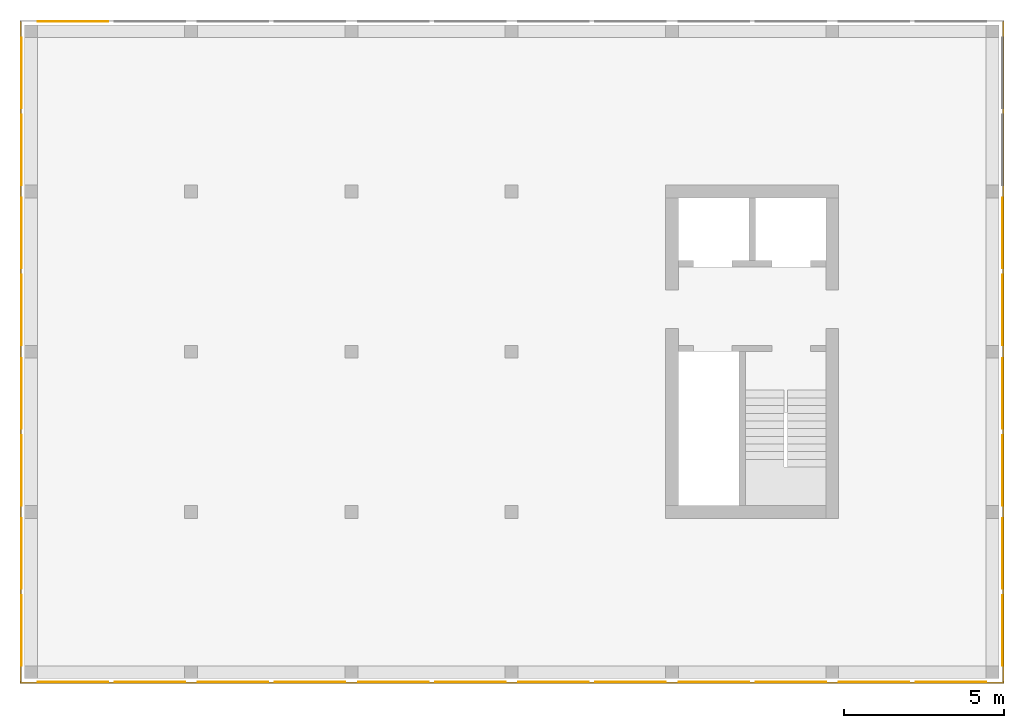
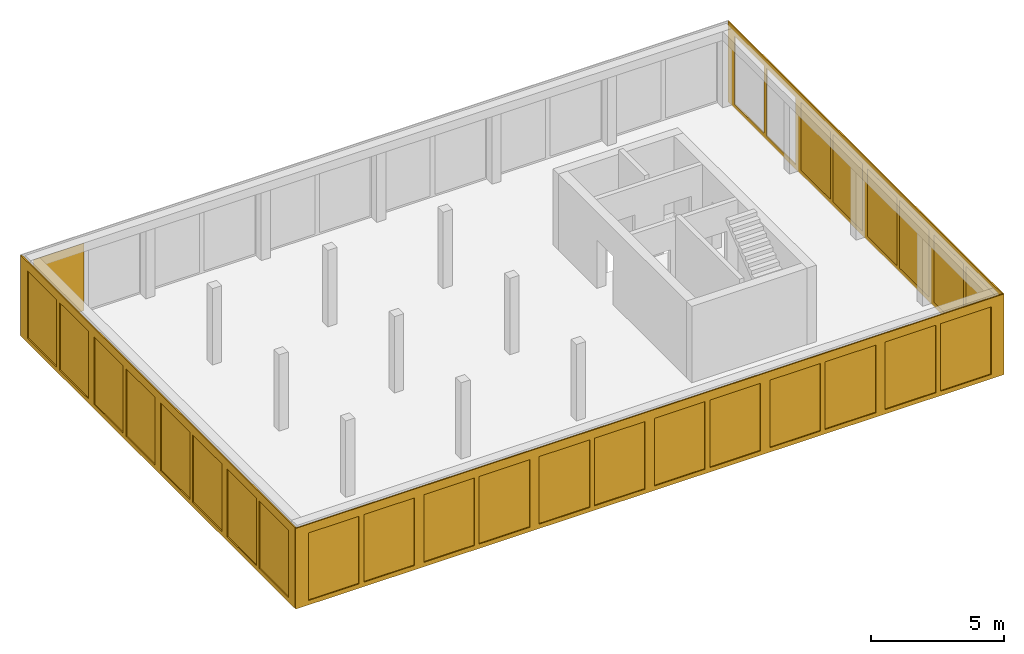
# One storey, part 3 of 4: 30 curtain walls.
"""IFC2X3 building model written with IfcOpenShell, lengths in metres."""

from ifc_helpers import new_model, entity, si_unit, converted_unit, frame, origin, place, context, subcontext, project, spatial, faceted_brep, material, element, save


model = new_model("IFC2X3")

# Units and contexts
model_context = context("Model", 3, precision=1e-05, world=origin())
body_context = subcontext(model_context, "Body", "Model", "MODEL_VIEW")
ifc_project = project(units=[si_unit("LENGTHUNIT", "METRE"), si_unit("AREAUNIT", "SQUARE_METRE"), si_unit("VOLUMEUNIT", "CUBIC_METRE"), si_unit("MASSUNIT", "GRAM", prefix="KILO"), converted_unit("PLANEANGLEUNIT", "DEGREE", entity("IfcPlaneAngleMeasure", 0.0174532925199433), si_unit("PLANEANGLEUNIT", "RADIAN"), dimensions=[0, 0, 0, 0, 0, 0, 0])], contexts=[model_context])

# Site, building, storey
site_placement = place(None, origin())
site = spatial("IfcSite", under=ifc_project, at=site_placement, CompositionType="ELEMENT")
building_placement = place(site_placement, origin())
building = spatial("IfcBuilding", under=site, at=building_placement, CompositionType="ELEMENT")
storey_placement = place(building_placement, frame((0.0, 0.0, 4.9)))
storey = spatial("IfcBuildingStorey", under=building, at=storey_placement, Name="1. Obergeschoss", CompositionType="ELEMENT", Elevation=4.9)

# Curtain walls
ifc_material_1 = material(Name="ALU")
curtain_wall_1_placement = place(storey_placement, frame((-0.139330706017223, -0.15, -0.2)))
element("IfcCurtainWall", 1, at=curtain_wall_1_placement, inside=storey, material=ifc_material_1, Name="Profil SN standard", context=body_context, shape_type="Brep", body=[
    faceted_brep([(30.7, 0.0500000000000003, 9.09494701772928e-16), (0.0, 0.0500000000000003, 9.09494701772928e-16), (0.0, 3.41060513164848e-16, 9.09494701772928e-16), (30.7, 3.41060513164848e-16, 9.09494701772928e-16), (0.0, 0.0500000000000004, 3.7), (30.7, 0.0500000000000003, 3.7), (30.7, 3.41060513164848e-16, 3.7), (0.0, 3.41060513164848e-16, 3.7), (25.15, 5.6843418860808e-17, 0.2), (25.15, 0.0500000000000001, 0.2), (25.15, 0.0500000000000001, 3.3), (25.15, 5.6843418860808e-17, 3.3), (25.55, 0.0500000000000001, 0.2), (25.55, 5.6843418860808e-17, 0.2), (25.55, 5.6843418860808e-17, 3.3), (25.55, 0.0500000000000001, 3.3), (20.15, 8.5265128291212e-17, 0.2), (20.15, 0.0500000000000001, 0.2), (20.15, 0.0500000000000001, 3.3), (20.15, 8.5265128291212e-17, 3.3), (20.55, 0.0500000000000001, 0.2), (20.55, 8.5265128291212e-17, 0.2), (20.55, 8.5265128291212e-17, 3.3), (20.55, 0.0500000000000001, 3.3), (30.15, 0.0, 0.2), (30.15, 0.05, 0.2), (30.15, 0.05, 3.3), (30.15, 0.0, 3.3), (22.75, 2.8421709430404e-16, 0.2), (22.75, 0.0500000000000003, 0.2), (22.75, 0.0500000000000003, 3.3), (22.75, 2.8421709430404e-16, 3.3), (22.95, 0.0500000000000003, 0.2), (22.95, 2.8421709430404e-16, 0.2), (22.95, 2.8421709430404e-16, 3.3), (22.95, 0.0500000000000003, 3.3), (17.75, 3.41060513164848e-16, 0.200000000000001), (17.75, 0.0500000000000003, 0.200000000000001), (17.75, 0.0500000000000003, 3.3), (17.75, 3.41060513164848e-16, 3.3), (17.95, 0.0500000000000003, 0.200000000000001), (17.95, 3.41060513164848e-16, 0.200000000000001), (17.95, 3.41060513164848e-16, 3.3), (17.95, 0.0500000000000003, 3.3), (27.75, 3.41060513164848e-16, 0.200000000000001), (27.75, 0.0500000000000003, 0.200000000000001), (27.75, 0.0500000000000003, 3.3), (27.75, 3.41060513164848e-16, 3.3), (27.95, 0.0500000000000003, 0.200000000000001), (27.95, 3.41060513164848e-16, 0.200000000000001), (27.95, 3.41060513164848e-16, 3.3), (27.95, 0.0500000000000003, 3.3), (2.75, 3.41060513164848e-16, 0.200000000000001), (2.75, 0.0500000000000003, 0.200000000000001), (2.75, 0.0500000000000003, 3.3), (2.75, 3.41060513164848e-16, 3.3), (2.95, 0.0500000000000003, 0.200000000000001), (2.95, 3.41060513164848e-16, 0.200000000000001), (2.95, 3.41060513164848e-16, 3.3), (2.95, 0.0500000000000003, 3.3), (12.75, 3.41060513164848e-16, 0.200000000000001), (12.75, 0.0500000000000003, 0.200000000000001), (12.75, 0.0500000000000003, 3.3), (12.75, 3.41060513164848e-16, 3.3), (12.95, 0.0500000000000003, 0.200000000000001), (12.95, 3.41060513164848e-16, 0.200000000000001), (12.95, 3.41060513164848e-16, 3.3), (12.95, 0.0500000000000003, 3.3), (7.75, 3.41060513164848e-16, 0.200000000000001), (7.75, 0.0500000000000003, 0.200000000000001), (7.75, 0.0500000000000003, 3.3), (7.75, 3.41060513164848e-16, 3.3), (7.95, 0.0500000000000003, 0.200000000000001), (7.95, 3.41060513164848e-16, 0.200000000000001), (7.95, 3.41060513164848e-16, 3.3), (7.95, 0.0500000000000003, 3.3), (15.55, 3.41060513164848e-16, 0.200000000000001), (15.55, 0.0500000000000003, 0.200000000000001), (15.55, 3.41060513164848e-16, 3.3), (15.55, 0.0500000000000003, 3.3), (10.55, 0.0500000000000002, 3.3), (10.55, 1.70530256582424e-16, 3.3), (15.15, 3.41060513164848e-16, 3.3), (15.15, 0.0500000000000003, 3.3), (15.15, 3.41060513164848e-16, 0.200000000000001), (15.15, 0.0500000000000003, 0.200000000000001), (10.55, 3.41060513164848e-16, 0.200000000000001), (10.55, 0.0500000000000003, 0.200000000000001), (0.550000000000004, 0.0500000000000003, 3.3), (0.550000000000004, 2.8421709430404e-16, 3.3), (5.15, 2.27373675443232e-16, 3.3), (5.15, 0.0500000000000003, 3.3), (5.15, 3.41060513164848e-16, 0.200000000000001), (5.15, 0.0500000000000003, 0.200000000000001), (0.550000000000004, 2.8421709430404e-16, 0.2), (0.550000000000004, 0.0500000000000003, 0.2), (5.55, 0.0500000000000003, 0.200000000000001), (5.55, 3.41060513164848e-16, 0.200000000000001), (5.55, 2.27373675443232e-16, 3.3), (5.55, 0.0500000000000003, 3.3), (10.15, 1.70530256582424e-16, 3.3), (10.15, 0.0500000000000002, 3.3), (10.15, 3.41060513164848e-16, 0.200000000000001), (10.15, 0.0500000000000003, 0.200000000000001)], [[[0, 1, 2, 3]], [[4, 5, 6, 7]], [[3, 6, 5, 0]], [[1, 4, 7, 2]], [[8, 9, 10, 11]], [[12, 13, 14, 15]], [[16, 17, 18, 19]], [[20, 21, 22, 23]], [[24, 25, 26, 27]], [[28, 29, 30, 31]], [[32, 33, 34, 35]], [[36, 37, 38, 39]], [[40, 41, 42, 43]], [[44, 45, 46, 47]], [[48, 49, 50, 51]], [[52, 53, 54, 55]], [[56, 57, 58, 59]], [[60, 61, 62, 63]], [[64, 65, 66, 67]], [[68, 69, 70, 71]], [[72, 73, 74, 75]], [[36, 76, 77, 37]], [[77, 76, 78, 79]], [[38, 79, 78, 39]], [[62, 80, 81, 63]], [[66, 82, 83, 67]], [[84, 85, 83, 82]], [[64, 85, 84, 65]], [[60, 86, 87, 61]], [[87, 86, 81, 80]], [[54, 88, 89, 55]], [[58, 90, 91, 59]], [[92, 93, 91, 90]], [[56, 93, 92, 57]], [[52, 94, 95, 53]], [[95, 94, 89, 88]], [[96, 97, 98, 99]], [[70, 99, 98, 71]], [[74, 100, 101, 75]], [[102, 103, 101, 100]], [[72, 103, 102, 73]], [[68, 97, 96, 69]], [[16, 41, 40, 17]], [[20, 29, 28, 21]], [[8, 33, 32, 9]], [[12, 45, 44, 13]], [[22, 31, 30, 23]], [[18, 43, 42, 19]], [[14, 47, 46, 15]], [[10, 35, 34, 11]], [[24, 49, 48, 25]], [[26, 51, 50, 27]], [[6, 3, 2, 7], [97, 68, 71, 98], [89, 94, 52, 55], [81, 86, 60, 63], [73, 102, 100, 74], [65, 84, 82, 66], [57, 92, 90, 58], [78, 76, 36, 39], [27, 50, 49, 24], [21, 28, 31, 22], [42, 41, 16, 19], [13, 44, 47, 14], [34, 33, 8, 11]], [[4, 1, 0, 5], [93, 56, 59, 91], [101, 103, 72, 75], [85, 64, 67, 83], [69, 96, 99, 70], [61, 87, 80, 62], [53, 95, 88, 54], [37, 77, 79, 38], [25, 48, 51, 26], [17, 40, 43, 18], [30, 29, 20, 23], [9, 32, 35, 10], [46, 45, 12, 15]]], orient=[[False], [False], [False], [False], [False], [False], [False], [False], [False], [False], [False], [False], [False], [False], [False], [False], [False], [False], [False], [False], [False], [False], [False], [False], [False], [False], [False], [False], [False], [False], [False], [False], [False], [False], [False], [False], [False], [False], [False], [False], [False], [False], [False], [False], [False], [False], [False], [False], [False], [False], [False], [False], [False, False, False, False, False, False, False, False, False, False, False, False, False], [False, False, False, False, False, False, False, False, False, False, False, False, False]]),
])
ifc_material_2 = material(Name="ALU")
curtain_wall_2_placement = place(storey_placement, frame((30.5106692939828, -0.1, -0.2)))
element("IfcCurtainWall", 2, at=curtain_wall_2_placement, inside=storey, material=ifc_material_2, Name="Profil OW standard", context=body_context, shape_type="Brep", body=[
    faceted_brep([(0.05, 20.6, 3.7), (0.05, 0.0, 3.7), (0.0, 0.0, 3.7), (0.0, 20.6, 3.7), (0.05, 0.0, 0.0), (0.05, 20.6, 0.0), (0.0, 20.6, 0.0), (0.0, 0.0, 0.0), (3.63797880709171e-15, 0.500000000000022, 0.2), (0.0500000000000036, 0.500000000000022, 0.2), (0.0500000000000036, 0.500000000000022, 3.3), (3.63797880709171e-15, 0.500000000000022, 3.3), (0.05, 2.70000000000003, 0.2), (0.0, 2.70000000000003, 0.2), (0.0, 2.70000000000003, 3.3), (0.05, 2.70000000000003, 3.3), (0.05, 2.90000000000003, 0.2), (0.05, 2.90000000000003, 3.3), (0.0, 2.90000000000003, 3.3), (0.0, 2.90000000000003, 0.2), (0.0, 7.70000000000003, 0.2), (0.0, 7.70000000000003, 3.3), (0.05, 7.70000000000003, 3.3), (0.05, 7.70000000000003, 0.2), (0.05, 7.90000000000003, 0.2), (0.05, 7.90000000000003, 3.3), (0.0, 7.90000000000003, 3.3), (0.0, 7.90000000000003, 0.2), (0.0, 12.7, 0.2), (0.0, 12.7, 3.3), (0.05, 12.7, 3.3), (0.05, 12.7, 0.2), (0.05, 12.9, 0.2), (0.05, 12.9, 3.3), (0.0, 12.9, 3.3), (0.0, 12.9, 0.2), (0.0, 5.50000000000002, 0.2), (0.05, 5.50000000000002, 0.2), (0.05, 5.10000000000002, 0.2), (0.0, 5.10000000000002, 0.2), (0.0, 5.10000000000002, 3.3), (0.05, 5.10000000000002, 3.3), (0.05, 5.50000000000002, 3.3), (0.0, 5.50000000000002, 3.3), (0.0, 10.5, 0.2), (0.05, 10.5, 0.2), (0.05, 10.1, 0.2), (0.0, 10.1, 0.2), (0.0, 10.1, 3.3), (0.05, 10.1, 3.3), (0.05, 10.5, 3.3), (0.0, 10.5, 3.3), (0.05, 15.1, 0.2), (0.0, 15.1, 0.2), (0.0, 15.1, 3.3), (0.05, 15.1, 3.3), (0.0, 15.5, 0.2), (0.05, 15.5, 0.2), (0.05, 15.5, 3.3), (0.0, 15.5, 3.3), (0.05, 20.1, 0.2), (0.0, 20.1, 0.2), (0.0, 20.1, 3.3), (0.05, 20.1, 3.3), (0.05, 17.7, 0.2), (0.0, 17.7, 0.2), (0.0, 17.9, 0.2), (0.05, 17.9, 0.2), (0.05, 17.9, 3.3), (0.0, 17.9, 3.3), (0.0, 17.7, 3.3), (0.05, 17.7, 3.3)], [[[0, 1, 2, 3]], [[4, 5, 6, 7]], [[8, 9, 10, 11]], [[7, 2, 1, 4]], [[12, 9, 8, 13]], [[14, 11, 10, 15]], [[13, 14, 15, 12]], [[16, 17, 18, 19]], [[20, 21, 22, 23]], [[24, 25, 26, 27]], [[28, 29, 30, 31]], [[32, 33, 34, 35]], [[36, 20, 23, 37]], [[38, 16, 19, 39]], [[40, 18, 17, 41]], [[42, 22, 21, 43]], [[36, 37, 42, 43]], [[38, 39, 40, 41]], [[44, 28, 31, 45]], [[46, 24, 27, 47]], [[48, 26, 25, 49]], [[50, 30, 29, 51]], [[44, 45, 50, 51]], [[46, 47, 48, 49]], [[52, 32, 35, 53]], [[54, 34, 33, 55]], [[56, 57, 58, 59]], [[52, 53, 54, 55]], [[5, 0, 3, 6]], [[60, 61, 62, 63]], [[64, 57, 56, 65]], [[66, 61, 60, 67]], [[68, 63, 62, 69]], [[70, 59, 58, 71]], [[65, 70, 71, 64]], [[67, 68, 69, 66]], [[2, 7, 6, 3], [13, 8, 11, 14], [39, 19, 18, 40], [21, 20, 36, 43], [47, 27, 26, 48], [29, 28, 44, 51], [53, 35, 34, 54], [65, 56, 59, 70], [62, 61, 66, 69]], [[4, 1, 0, 5], [15, 10, 9, 12], [41, 17, 16, 38], [23, 22, 42, 37], [49, 25, 24, 46], [31, 30, 50, 45], [33, 32, 52, 55], [67, 60, 63, 68], [58, 57, 64, 71]]], orient=[[False], [False], [False], [False], [False], [False], [False], [False], [False], [False], [False], [False], [False], [False], [False], [False], [False], [False], [False], [False], [False], [False], [False], [False], [False], [False], [False], [False], [False], [False], [False], [False], [False], [False], [False], [False], [False, False, False, False, False, False, False, False, False], [False, False, False, False, False, False, False, False, False]]),
])
ifc_material_3 = material(Name="ALU")
curtain_wall_3_placement = place(storey_placement, frame((-0.139330706017224, -0.1, -0.2)))
element("IfcCurtainWall", 3, at=curtain_wall_3_placement, inside=storey, material=ifc_material_3, Name="Profil OW standard", context=body_context, shape_type="Brep", body=[
    faceted_brep([(0.0500000000000026, 0.0, 9.09494701772928e-16), (0.0500000000000026, 20.6, 9.09494701772928e-16), (2.55795384873636e-15, 20.6, 9.09494701772928e-16), (2.58637555816676e-15, 0.0, 9.09494701772928e-16), (0.0500000000000026, 20.6, 3.7), (0.0500000000000026, 0.0, 3.7), (2.58637555816676e-15, 0.0, 3.7), (2.55795384873636e-15, 20.6, 3.7), (0.0500000000000012, 10.1, 0.2), (1.10844666778576e-15, 10.1, 0.2), (1.10844666778576e-15, 10.1, 3.3), (0.0500000000000012, 10.1, 3.3), (1.08002495835535e-15, 10.5, 0.2), (0.0500000000000011, 10.5, 0.2), (0.0500000000000011, 10.5, 3.3), (1.08002495835535e-15, 10.5, 3.3), (1.62003743753303e-15, 5.50000000000002, 0.2), (0.0500000000000017, 5.50000000000002, 0.2), (0.0500000000000017, 5.50000000000002, 3.3), (1.62003743753303e-15, 5.50000000000002, 3.3), (0.0500000000000017, 5.10000000000002, 0.2), (1.67688085639384e-15, 5.10000000000002, 0.2), (1.67688085639384e-15, 5.10000000000002, 3.3), (0.0500000000000017, 5.10000000000002, 3.3), (5.11590769747272e-16, 15.5, 0.2), (0.0500000000000005, 15.5, 0.2), (0.0500000000000005, 15.5, 3.3), (5.11590769747272e-16, 15.5, 3.3), (0.0500000000000006, 15.1, 0.2), (5.6843418860808e-16, 15.1, 0.2), (5.6843418860808e-16, 15.1, 3.3), (0.0500000000000006, 15.1, 3.3), (0.05, 20.1, 0.2), (0.0, 20.1, 0.2), (0.0, 20.1, 3.3), (0.05, 20.1, 3.3), (2.18847162614111e-15, 7.90000000000002, 0.2), (0.0500000000000022, 7.90000000000002, 0.2), (0.0500000000000022, 7.90000000000002, 3.3), (2.18847162614111e-15, 7.90000000000002, 3.3), (0.0500000000000023, 7.70000000000002, 0.2), (2.24531504500192e-15, 7.70000000000002, 0.2), (2.24531504500192e-15, 7.70000000000002, 3.3), (0.0500000000000023, 7.70000000000002, 3.3), (2.18847162614111e-15, 2.90000000000002, 0.2), (0.0500000000000022, 2.90000000000002, 0.2), (0.0500000000000022, 2.90000000000002, 3.3), (2.18847162614111e-15, 2.90000000000002, 3.3), (0.0500000000000023, 2.70000000000002, 0.2), (2.24531504500192e-15, 2.70000000000002, 0.2), (2.24531504500192e-15, 2.70000000000002, 3.3), (0.0500000000000023, 2.70000000000002, 3.3), (2.18847162614111e-15, 17.9, 0.2), (0.0500000000000022, 17.9, 0.2), (0.0500000000000022, 17.9, 3.3), (2.18847162614111e-15, 17.9, 3.3), (0.0500000000000023, 17.7, 0.2), (2.24531504500192e-15, 17.7, 0.2), (2.24531504500192e-15, 17.7, 3.3), (0.0500000000000023, 17.7, 3.3), (2.24531504500192e-15, 12.7, 3.3), (0.0500000000000023, 12.7, 3.3), (2.18847162614111e-15, 12.9, 3.3), (0.0500000000000022, 12.9, 3.3), (0.0500000000000022, 12.9, 0.2), (2.18847162614111e-15, 12.9, 0.2), (0.0500000000000023, 12.7, 0.2), (2.24531504500192e-15, 12.7, 0.2), (0.0500000000000026, 0.500000000000022, 0.200000000000001), (2.58637555816676e-15, 0.500000000000022, 0.200000000000001), (0.0500000000000026, 0.500000000000022, 3.3), (2.58637555816676e-15, 0.500000000000022, 3.3)], [[[0, 1, 2, 3]], [[4, 5, 6, 7]], [[8, 9, 10, 11]], [[12, 13, 14, 15]], [[3, 6, 5, 0]], [[16, 17, 18, 19]], [[20, 21, 22, 23]], [[1, 4, 7, 2]], [[24, 25, 26, 27]], [[28, 29, 30, 31]], [[32, 33, 34, 35]], [[36, 37, 38, 39]], [[40, 41, 42, 43]], [[44, 45, 46, 47]], [[48, 49, 50, 51]], [[52, 53, 54, 55]], [[56, 57, 58, 59]], [[60, 15, 14, 61]], [[30, 62, 63, 31]], [[26, 59, 58, 27]], [[34, 55, 54, 35]], [[32, 53, 52, 33]], [[24, 57, 56, 25]], [[28, 64, 65, 29]], [[66, 13, 12, 67]], [[36, 9, 8, 37]], [[16, 41, 40, 17]], [[20, 45, 44, 21]], [[48, 68, 69, 49]], [[69, 68, 70, 71]], [[50, 71, 70, 51]], [[22, 47, 46, 23]], [[18, 43, 42, 19]], [[38, 11, 10, 39]], [[65, 64, 63, 62]], [[66, 67, 60, 61]], [[2, 7, 6, 3], [69, 71, 50, 49], [39, 10, 9, 36], [33, 52, 55, 34], [29, 65, 62, 30], [58, 57, 24, 27], [19, 42, 41, 16], [44, 47, 22, 21], [60, 67, 12, 15]], [[0, 5, 4, 1], [51, 70, 68, 48], [13, 66, 61, 14], [35, 54, 53, 32], [31, 63, 64, 28], [56, 59, 26, 25], [23, 46, 45, 20], [40, 43, 18, 17], [38, 37, 8, 11]]], orient=[[False], [False], [False], [False], [False], [False], [False], [False], [False], [False], [False], [False], [False], [False], [False], [False], [False], [False], [False], [False], [False], [False], [False], [False], [False], [False], [False], [False], [False], [False], [False], [False], [False], [False], [False], [False], [False, False, False, False, False, False, False, False, False], [False, False, False, False, False, False, False, False, False]]),
])
ifc_material_4 = material(Name="VSG")
curtain_wall_4_placement = place(storey_placement, frame((-0.0943307060172242, 17.8, 0.0)))
element("IfcCurtainWall", 4, at=curtain_wall_4_placement, inside=storey, material=ifc_material_4, Name="standard", context=body_context, shape_type="Brep", body=[
    faceted_brep([(0.005, -3.63797880709171e-15, 0.0), (0.0, -3.63797880709171e-15, 0.0), (0.0, -3.63797880709171e-15, 3.1), (0.005, -3.63797880709171e-15, 3.1), (0.0, 2.2, 0.0), (0.0, 2.2, 3.1), (0.005, 2.2, 0.0), (0.005, 2.2, 3.1)], [[[0, 1, 2, 3]], [[1, 4, 5, 2]], [[4, 6, 7, 5]], [[6, 0, 3, 7]], [[7, 3, 2, 5]], [[0, 6, 4, 1]]], orient=[[False], [False], [False], [False], [False], [False]]),
])
ifc_material_5 = material(Name="VSG")
curtain_wall_5_placement = place(storey_placement, frame((-0.0943307060172219, 15.4, 0.0)))
element("IfcCurtainWall", 5, at=curtain_wall_5_placement, inside=storey, material=ifc_material_5, Name="standard", context=body_context, shape_type="Brep", body=[
    faceted_brep([(0.005, -1.81898940354586e-15, 0.0), (0.0, -1.81898940354586e-15, 0.0), (0.0, -1.81898940354586e-15, 3.1), (0.005, -1.81898940354586e-15, 3.1), (0.0, 2.2, 0.0), (0.0, 2.2, 3.1), (0.005, 2.2, 0.0), (0.005, 2.2, 3.1)], [[[0, 1, 2, 3]], [[1, 4, 5, 2]], [[4, 6, 7, 5]], [[6, 0, 3, 7]], [[7, 3, 2, 5]], [[0, 6, 4, 1]]], orient=[[False], [False], [False], [False], [False], [False]]),
])
ifc_material_6 = material(Name="VSG")
curtain_wall_6_placement = place(storey_placement, frame((-0.0943307060172236, 12.8, 0.0)))
element("IfcCurtainWall", 6, at=curtain_wall_6_placement, inside=storey, material=ifc_material_6, Name="standard", context=body_context, shape_type="Brep", body=[
    faceted_brep([(0.005, 0.0, 0.0), (0.0, 0.0, 0.0), (0.0, 0.0, 3.1), (0.005, 0.0, 3.1), (0.0, 2.2, 0.0), (0.0, 2.2, 3.1), (0.005, 2.2, 0.0), (0.005, 2.2, 3.1)], [[[0, 1, 2, 3]], [[1, 4, 5, 2]], [[4, 6, 7, 5]], [[6, 0, 3, 7]], [[7, 3, 2, 5]], [[0, 6, 4, 1]]], orient=[[False], [False], [False], [False], [False], [False]]),
])
ifc_material_7 = material(Name="VSG")
curtain_wall_7_placement = place(storey_placement, frame((-0.0943307060172219, 10.4, 0.0)))
element("IfcCurtainWall", 7, at=curtain_wall_7_placement, inside=storey, material=ifc_material_7, Name="standard", context=body_context, shape_type="Brep", body=[
    faceted_brep([(0.005, 0.0, 0.0), (0.0, 0.0, 0.0), (0.0, 0.0, 3.1), (0.005, 0.0, 3.1), (0.0, 2.2, 0.0), (0.0, 2.2, 3.1), (0.005, 2.2, 0.0), (0.005, 2.2, 3.1)], [[[0, 1, 2, 3]], [[1, 4, 5, 2]], [[4, 6, 7, 5]], [[6, 0, 3, 7]], [[7, 3, 2, 5]], [[0, 6, 4, 1]]], orient=[[False], [False], [False], [False], [False], [False]]),
])
ifc_material_8 = material(Name="VSG")
curtain_wall_8_placement = place(storey_placement, frame((-0.0943307060172231, 7.80000000000001, 0.0)))
element("IfcCurtainWall", 8, at=curtain_wall_8_placement, inside=storey, material=ifc_material_8, Name="standard", context=body_context, shape_type="Brep", body=[
    faceted_brep([(0.005, 0.0, 0.0), (0.0, 0.0, 0.0), (0.0, 0.0, 3.1), (0.005, 0.0, 3.1), (0.0, 2.2, 0.0), (0.0, 2.2, 3.1), (0.005, 2.2, 0.0), (0.005, 2.2, 3.1)], [[[0, 1, 2, 3]], [[1, 4, 5, 2]], [[4, 6, 7, 5]], [[6, 0, 3, 7]], [[7, 3, 2, 5]], [[0, 6, 4, 1]]], orient=[[False], [False], [False], [False], [False], [False]]),
])
ifc_material_9 = material(Name="VSG")
curtain_wall_9_placement = place(storey_placement, frame((-0.0943307060172219, 5.40000000000002, 0.0)))
element("IfcCurtainWall", 9, at=curtain_wall_9_placement, inside=storey, material=ifc_material_9, Name="standard", context=body_context, shape_type="Brep", body=[
    faceted_brep([(0.005, 0.0, 0.0), (0.0, 0.0, 0.0), (0.0, 0.0, 3.1), (0.005, 0.0, 3.1), (0.0, 2.2, 0.0), (0.0, 2.2, 3.1), (0.005, 2.2, 0.0), (0.005, 2.2, 3.1)], [[[0, 1, 2, 3]], [[1, 4, 5, 2]], [[4, 6, 7, 5]], [[6, 0, 3, 7]], [[7, 3, 2, 5]], [[0, 6, 4, 1]]], orient=[[False], [False], [False], [False], [False], [False]]),
])
ifc_material_10 = material(Name="VSG")
curtain_wall_10_placement = place(storey_placement, frame((-0.0943307060172225, 2.80000000000001, 0.0)))
element("IfcCurtainWall", 10, at=curtain_wall_10_placement, inside=storey, material=ifc_material_10, Name="standard", context=body_context, shape_type="Brep", body=[
    faceted_brep([(0.005, 0.0, 0.0), (0.0, 0.0, 0.0), (0.0, 0.0, 3.1), (0.005, 0.0, 3.1), (0.0, 2.2, 0.0), (0.0, 2.2, 3.1), (0.005, 2.2, 0.0), (0.005, 2.2, 3.1)], [[[0, 1, 2, 3]], [[1, 4, 5, 2]], [[4, 6, 7, 5]], [[6, 0, 3, 7]], [[7, 3, 2, 5]], [[0, 6, 4, 1]]], orient=[[False], [False], [False], [False], [False], [False]]),
])
ifc_material_11 = material(Name="VSG")
curtain_wall_11_placement = place(storey_placement, frame((-0.0943307060172219, 0.400000000000018, 0.0)))
element("IfcCurtainWall", 11, at=curtain_wall_11_placement, inside=storey, material=ifc_material_11, Name="standard", context=body_context, shape_type="Brep", body=[
    faceted_brep([(0.005, 0.0, 0.0), (0.0, 0.0, 0.0), (0.0, 0.0, 3.1), (0.005, 0.0, 3.1), (0.0, 2.2, 0.0), (0.0, 2.2, 3.1), (0.005, 2.2, 0.0), (0.005, 2.2, 3.1)], [[[0, 1, 2, 3]], [[1, 4, 5, 2]], [[4, 6, 7, 5]], [[6, 0, 3, 7]], [[7, 3, 2, 5]], [[0, 6, 4, 1]]], orient=[[False], [False], [False], [False], [False], [False]]),
])
ifc_material_12 = material(Name="VSG")
curtain_wall_12_placement = place(storey_placement, frame((0.410669293982781, -0.105, 0.0)))
element("IfcCurtainWall", 12, at=curtain_wall_12_placement, inside=storey, material=ifc_material_12, Name="standard", context=body_context, shape_type="Brep", body=[
    faceted_brep([(2.2, 0.00500000000000001, 0.0), (2.2, 1.4210854715202e-17, 0.0), (2.2, 1.4210854715202e-17, 3.1), (2.2, 0.00500000000000001, 3.1), (0.0, 2.8421709430404e-16, 0.0), (0.0, 2.8421709430404e-16, 3.1), (0.0, 0.00500000000000028, 0.0), (0.0, 0.00500000000000028, 3.1)], [[[0, 1, 2, 3]], [[1, 4, 5, 2]], [[4, 6, 7, 5]], [[6, 0, 3, 7]], [[7, 3, 2, 5]], [[0, 6, 4, 1]]], orient=[[False], [False], [False], [False], [False], [False]]),
])
ifc_material_13 = material(Name="VSG")
curtain_wall_13_placement = place(storey_placement, frame((2.81066929398278, -0.105, 0.0)))
element("IfcCurtainWall", 13, at=curtain_wall_13_placement, inside=storey, material=ifc_material_13, Name="standard", context=body_context, shape_type="Brep", body=[
    faceted_brep([(2.2, 0.00500000000000001, 0.0), (2.2, 1.4210854715202e-17, 0.0), (2.2, 1.4210854715202e-17, 3.1), (2.2, 0.00500000000000001, 3.1), (0.0, 2.8421709430404e-16, 0.0), (0.0, 2.8421709430404e-16, 3.1), (0.0, 0.00500000000000028, 0.0), (0.0, 0.00500000000000028, 3.1)], [[[0, 1, 2, 3]], [[1, 4, 5, 2]], [[4, 6, 7, 5]], [[6, 0, 3, 7]], [[7, 3, 2, 5]], [[0, 6, 4, 1]]], orient=[[False], [False], [False], [False], [False], [False]]),
])
ifc_material_14 = material(Name="VSG")
curtain_wall_14_placement = place(storey_placement, frame((5.41066929398277, -0.105, 0.0)))
element("IfcCurtainWall", 14, at=curtain_wall_14_placement, inside=storey, material=ifc_material_14, Name="standard", context=body_context, shape_type="Brep", body=[
    faceted_brep([(2.2, 0.00500000000000001, 0.0), (2.2, 1.4210854715202e-17, 0.0), (2.2, 1.4210854715202e-17, 3.1), (2.2, 0.00500000000000001, 3.1), (0.0, 2.8421709430404e-16, 0.0), (0.0, 2.8421709430404e-16, 3.1), (0.0, 0.00500000000000028, 0.0), (0.0, 0.00500000000000028, 3.1)], [[[0, 1, 2, 3]], [[1, 4, 5, 2]], [[4, 6, 7, 5]], [[6, 0, 3, 7]], [[7, 3, 2, 5]], [[0, 6, 4, 1]]], orient=[[False], [False], [False], [False], [False], [False]]),
])
ifc_material_15 = material(Name="VSG")
curtain_wall_15_placement = place(storey_placement, frame((7.81066929398278, -0.105, 0.0)))
element("IfcCurtainWall", 15, at=curtain_wall_15_placement, inside=storey, material=ifc_material_15, Name="standard", context=body_context, shape_type="Brep", body=[
    faceted_brep([(2.2, 0.00500000000000001, 0.0), (2.2, 1.4210854715202e-17, 0.0), (2.2, 1.4210854715202e-17, 3.1), (2.2, 0.00500000000000001, 3.1), (0.0, 2.8421709430404e-16, 0.0), (0.0, 2.8421709430404e-16, 3.1), (0.0, 0.00500000000000028, 0.0), (0.0, 0.00500000000000028, 3.1)], [[[0, 1, 2, 3]], [[1, 4, 5, 2]], [[4, 6, 7, 5]], [[6, 0, 3, 7]], [[7, 3, 2, 5]], [[0, 6, 4, 1]]], orient=[[False], [False], [False], [False], [False], [False]]),
])
ifc_material_16 = material(Name="VSG")
curtain_wall_16_placement = place(storey_placement, frame((10.4106692939828, -0.105, 0.0)))
element("IfcCurtainWall", 16, at=curtain_wall_16_placement, inside=storey, material=ifc_material_16, Name="standard", context=body_context, shape_type="Brep", body=[
    faceted_brep([(2.2, 0.00500000000000001, 0.0), (2.2, 1.4210854715202e-17, 0.0), (2.2, 1.4210854715202e-17, 3.1), (2.2, 0.00500000000000001, 3.1), (0.0, 2.8421709430404e-16, 0.0), (0.0, 2.8421709430404e-16, 3.1), (0.0, 0.00500000000000028, 0.0), (0.0, 0.00500000000000028, 3.1)], [[[0, 1, 2, 3]], [[1, 4, 5, 2]], [[4, 6, 7, 5]], [[6, 0, 3, 7]], [[7, 3, 2, 5]], [[0, 6, 4, 1]]], orient=[[False], [False], [False], [False], [False], [False]]),
])
ifc_material_17 = material(Name="VSG")
curtain_wall_17_placement = place(storey_placement, frame((15.4106692939828, -0.105, 0.0)))
element("IfcCurtainWall", 17, at=curtain_wall_17_placement, inside=storey, material=ifc_material_17, Name="standard", context=body_context, shape_type="Brep", body=[
    faceted_brep([(2.20000000000001, 0.00500000000000001, 0.0), (2.20000000000001, 1.4210854715202e-17, 0.0), (2.20000000000001, 1.4210854715202e-17, 3.1), (2.20000000000001, 0.00500000000000001, 3.1), (1.81898940354586e-15, 2.8421709430404e-16, 0.0), (1.81898940354586e-15, 2.8421709430404e-16, 3.1), (1.81898940354586e-15, 0.00500000000000028, 0.0), (1.81898940354586e-15, 0.00500000000000028, 3.1)], [[[0, 1, 2, 3]], [[1, 4, 5, 2]], [[4, 6, 7, 5]], [[6, 0, 3, 7]], [[7, 3, 2, 5]], [[0, 6, 4, 1]]], orient=[[False], [False], [False], [False], [False], [False]]),
])
ifc_material_18 = material(Name="VSG")
curtain_wall_18_placement = place(storey_placement, frame((17.8106692939828, -0.105, 0.0)))
element("IfcCurtainWall", 18, at=curtain_wall_18_placement, inside=storey, material=ifc_material_18, Name="standard", context=body_context, shape_type="Brep", body=[
    faceted_brep([(2.2, 0.00500000000000001, 0.0), (2.2, 1.4210854715202e-17, 0.0), (2.2, 1.4210854715202e-17, 3.1), (2.2, 0.00500000000000001, 3.1), (0.0, 2.8421709430404e-16, 0.0), (0.0, 2.8421709430404e-16, 3.1), (0.0, 0.00500000000000028, 0.0), (0.0, 0.00500000000000028, 3.1)], [[[0, 1, 2, 3]], [[1, 4, 5, 2]], [[4, 6, 7, 5]], [[6, 0, 3, 7]], [[7, 3, 2, 5]], [[0, 6, 4, 1]]], orient=[[False], [False], [False], [False], [False], [False]]),
])
ifc_material_19 = material(Name="VSG")
curtain_wall_19_placement = place(storey_placement, frame((20.4106692939828, -0.105000000000001, 0.0)))
element("IfcCurtainWall", 19, at=curtain_wall_19_placement, inside=storey, material=ifc_material_19, Name="standard", context=body_context, shape_type="Brep", body=[
    faceted_brep([(2.2, 0.00500000000000001, 0.0), (2.2, 1.4210854715202e-17, 0.0), (2.2, 1.4210854715202e-17, 3.1), (2.2, 0.00500000000000001, 3.1), (0.0, 2.8421709430404e-16, 0.0), (0.0, 2.8421709430404e-16, 3.1), (0.0, 0.00500000000000028, 0.0), (0.0, 0.00500000000000028, 3.1)], [[[0, 1, 2, 3]], [[1, 4, 5, 2]], [[4, 6, 7, 5]], [[6, 0, 3, 7]], [[7, 3, 2, 5]], [[0, 6, 4, 1]]], orient=[[False], [False], [False], [False], [False], [False]]),
])
ifc_material_20 = material(Name="VSG")
curtain_wall_20_placement = place(storey_placement, frame((22.8106692939828, -0.105, 0.0)))
element("IfcCurtainWall", 20, at=curtain_wall_20_placement, inside=storey, material=ifc_material_20, Name="standard", context=body_context, shape_type="Brep", body=[
    faceted_brep([(2.2, 0.00500000000000001, 0.0), (2.2, 1.4210854715202e-17, 0.0), (2.2, 1.4210854715202e-17, 3.1), (2.2, 0.00500000000000001, 3.1), (0.0, 2.8421709430404e-16, 0.0), (0.0, 2.8421709430404e-16, 3.1), (0.0, 0.00500000000000028, 0.0), (0.0, 0.00500000000000028, 3.1)], [[[0, 1, 2, 3]], [[1, 4, 5, 2]], [[4, 6, 7, 5]], [[6, 0, 3, 7]], [[7, 3, 2, 5]], [[0, 6, 4, 1]]], orient=[[False], [False], [False], [False], [False], [False]]),
])
ifc_material_21 = material(Name="VSG")
curtain_wall_21_placement = place(storey_placement, frame((25.4106692939828, -0.105000000000001, 0.0)))
element("IfcCurtainWall", 21, at=curtain_wall_21_placement, inside=storey, material=ifc_material_21, Name="standard", context=body_context, shape_type="Brep", body=[
    faceted_brep([(2.2, 0.00500000000000001, 0.0), (2.2, 1.4210854715202e-17, 0.0), (2.2, 1.4210854715202e-17, 3.1), (2.2, 0.00500000000000001, 3.1), (0.0, 2.8421709430404e-16, 0.0), (0.0, 2.8421709430404e-16, 3.1), (0.0, 0.00500000000000028, 0.0), (0.0, 0.00500000000000028, 3.1)], [[[0, 1, 2, 3]], [[1, 4, 5, 2]], [[4, 6, 7, 5]], [[6, 0, 3, 7]], [[7, 3, 2, 5]], [[0, 6, 4, 1]]], orient=[[False], [False], [False], [False], [False], [False]]),
])
ifc_material_22 = material(Name="VSG")
curtain_wall_22_placement = place(storey_placement, frame((27.8106692939828, -0.105, 0.0)))
element("IfcCurtainWall", 22, at=curtain_wall_22_placement, inside=storey, material=ifc_material_22, Name="standard", context=body_context, shape_type="Brep", body=[
    faceted_brep([(2.2, 0.00500000000000001, 0.0), (2.2, 1.4210854715202e-17, 0.0), (2.2, 1.4210854715202e-17, 3.1), (2.2, 0.00500000000000001, 3.1), (0.0, 2.8421709430404e-16, 0.0), (0.0, 2.8421709430404e-16, 3.1), (0.0, 0.00500000000000028, 0.0), (0.0, 0.00500000000000028, 3.1)], [[[0, 1, 2, 3]], [[1, 4, 5, 2]], [[4, 6, 7, 5]], [[6, 0, 3, 7]], [[7, 3, 2, 5]], [[0, 6, 4, 1]]], orient=[[False], [False], [False], [False], [False], [False]]),
])
ifc_material_23 = material(Name="VSG")
curtain_wall_23_placement = place(storey_placement, frame((0.410669293982781, 20.5, 0.0)))
element("IfcCurtainWall", 23, at=curtain_wall_23_placement, inside=storey, material=ifc_material_23, Name="standard", context=body_context, shape_type="Brep", body=[
    faceted_brep([(2.2, 0.0, 0.0), (2.2, 0.0, 3.1), (2.2, 0.005, 3.1), (2.2, 0.005, 0.0), (0.0, 0.005, 3.1), (0.0, 0.005, 0.0), (0.0, 0.0, 3.1), (0.0, 0.0, 0.0)], [[[0, 1, 2, 3]], [[3, 2, 4, 5]], [[5, 4, 6, 7]], [[7, 6, 1, 0]], [[6, 4, 2, 1]], [[0, 3, 5, 7]]], orient=[[False], [False], [False], [False], [False], [False]]),
])
ifc_material_24 = material(Name="VSG")
curtain_wall_24_placement = place(storey_placement, frame((30.5106692939828, 12.8, 0.0)))
element("IfcCurtainWall", 24, at=curtain_wall_24_placement, inside=storey, material=ifc_material_24, Name="standard", context=body_context, shape_type="Brep", body=[
    faceted_brep([(0.0, 0.0, 0.0), (0.0, 0.0, 3.1), (0.005, 0.0, 3.1), (0.005, 0.0, 0.0), (0.005, 2.2, 3.1), (0.005, 2.2, 0.0), (0.0, 2.2, 3.1), (0.0, 2.2, 0.0)], [[[0, 1, 2, 3]], [[3, 2, 4, 5]], [[5, 4, 6, 7]], [[7, 6, 1, 0]], [[6, 4, 2, 1]], [[0, 3, 5, 7]]], orient=[[False], [False], [False], [False], [False], [False]]),
])
ifc_material_25 = material(Name="VSG")
curtain_wall_25_placement = place(storey_placement, frame((30.5106692939828, 10.4, 0.0)))
element("IfcCurtainWall", 25, at=curtain_wall_25_placement, inside=storey, material=ifc_material_25, Name="standard", context=body_context, shape_type="Brep", body=[
    faceted_brep([(0.0, 0.0, 0.0), (0.0, 0.0, 3.1), (0.005, 0.0, 3.1), (0.005, 0.0, 0.0), (0.005, 2.2, 3.1), (0.005, 2.2, 0.0), (0.0, 2.2, 3.1), (0.0, 2.2, 0.0)], [[[0, 1, 2, 3]], [[3, 2, 4, 5]], [[5, 4, 6, 7]], [[7, 6, 1, 0]], [[6, 4, 2, 1]], [[0, 3, 5, 7]]], orient=[[False], [False], [False], [False], [False], [False]]),
])
ifc_material_26 = material(Name="VSG")
curtain_wall_26_placement = place(storey_placement, frame((30.5106692939828, 7.80000000000001, 0.0)))
element("IfcCurtainWall", 26, at=curtain_wall_26_placement, inside=storey, material=ifc_material_26, Name="standard", context=body_context, shape_type="Brep", body=[
    faceted_brep([(0.0, 0.0, 0.0), (0.0, 0.0, 3.1), (0.005, 0.0, 3.1), (0.005, 0.0, 0.0), (0.005, 2.2, 3.1), (0.005, 2.2, 0.0), (0.0, 2.2, 3.1), (0.0, 2.2, 0.0)], [[[0, 1, 2, 3]], [[3, 2, 4, 5]], [[5, 4, 6, 7]], [[7, 6, 1, 0]], [[6, 4, 2, 1]], [[0, 3, 5, 7]]], orient=[[False], [False], [False], [False], [False], [False]]),
])
ifc_material_27 = material(Name="VSG")
curtain_wall_27_placement = place(storey_placement, frame((30.5106692939828, 5.40000000000002, 0.0)))
element("IfcCurtainWall", 27, at=curtain_wall_27_placement, inside=storey, material=ifc_material_27, Name="standard", context=body_context, shape_type="Brep", body=[
    faceted_brep([(0.0, 0.0, 0.0), (0.0, 0.0, 3.1), (0.005, 0.0, 3.1), (0.005, 0.0, 0.0), (0.005, 2.2, 3.1), (0.005, 2.2, 0.0), (0.0, 2.2, 3.1), (0.0, 2.2, 0.0)], [[[0, 1, 2, 3]], [[3, 2, 4, 5]], [[5, 4, 6, 7]], [[7, 6, 1, 0]], [[6, 4, 2, 1]], [[0, 3, 5, 7]]], orient=[[False], [False], [False], [False], [False], [False]]),
])
ifc_material_28 = material(Name="VSG")
curtain_wall_28_placement = place(storey_placement, frame((30.5106692939828, 2.80000000000001, 0.0)))
element("IfcCurtainWall", 28, at=curtain_wall_28_placement, inside=storey, material=ifc_material_28, Name="standard", context=body_context, shape_type="Brep", body=[
    faceted_brep([(0.0, 0.0, 0.0), (0.0, 0.0, 3.1), (0.005, 0.0, 3.1), (0.005, 0.0, 0.0), (0.005, 2.2, 3.1), (0.005, 2.2, 0.0), (0.0, 2.2, 3.1), (0.0, 2.2, 0.0)], [[[0, 1, 2, 3]], [[3, 2, 4, 5]], [[5, 4, 6, 7]], [[7, 6, 1, 0]], [[6, 4, 2, 1]], [[0, 3, 5, 7]]], orient=[[False], [False], [False], [False], [False], [False]]),
])
ifc_material_29 = material(Name="VSG")
curtain_wall_29_placement = place(storey_placement, frame((30.5106692939828, 0.400000000000018, 0.0)))
element("IfcCurtainWall", 29, at=curtain_wall_29_placement, inside=storey, material=ifc_material_29, Name="standard", context=body_context, shape_type="Brep", body=[
    faceted_brep([(0.0, 0.0, 0.0), (0.0, 0.0, 3.1), (0.005, 0.0, 3.1), (0.005, 0.0, 0.0), (0.005, 2.2, 3.1), (0.005, 2.2, 0.0), (0.0, 2.2, 3.1), (0.0, 2.2, 0.0)], [[[0, 1, 2, 3]], [[3, 2, 4, 5]], [[5, 4, 6, 7]], [[7, 6, 1, 0]], [[6, 4, 2, 1]], [[0, 3, 5, 7]]], orient=[[False], [False], [False], [False], [False], [False]]),
])
ifc_material_30 = material(Name="VSG")
curtain_wall_30_placement = place(storey_placement, frame((12.8106692939828, -0.105, 0.0)))
element("IfcCurtainWall", 30, at=curtain_wall_30_placement, inside=storey, material=ifc_material_30, Name="standard", context=body_context, shape_type="Brep", body=[
    faceted_brep([(2.2, 0.00500000000000001, 0.0), (2.2, 1.4210854715202e-17, 0.0), (2.2, 1.4210854715202e-17, 3.1), (2.2, 0.00500000000000001, 3.1), (0.0, 2.8421709430404e-16, 0.0), (0.0, 2.8421709430404e-16, 3.1), (0.0, 0.00500000000000028, 0.0), (0.0, 0.00500000000000028, 3.1)], [[[0, 1, 2, 3]], [[1, 4, 5, 2]], [[4, 6, 7, 5]], [[6, 0, 3, 7]], [[7, 3, 2, 5]], [[0, 6, 4, 1]]], orient=[[False], [False], [False], [False], [False], [False]]),
])

save(model, "model.ifc")
